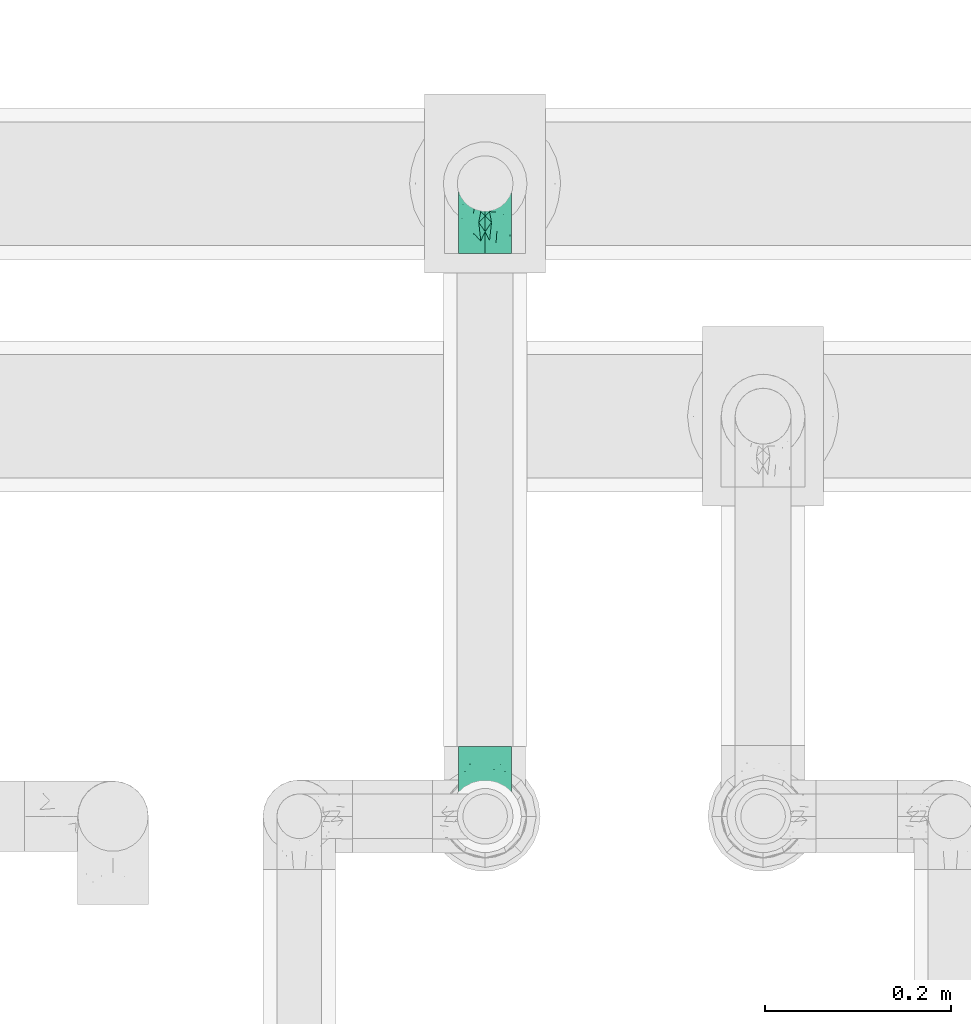
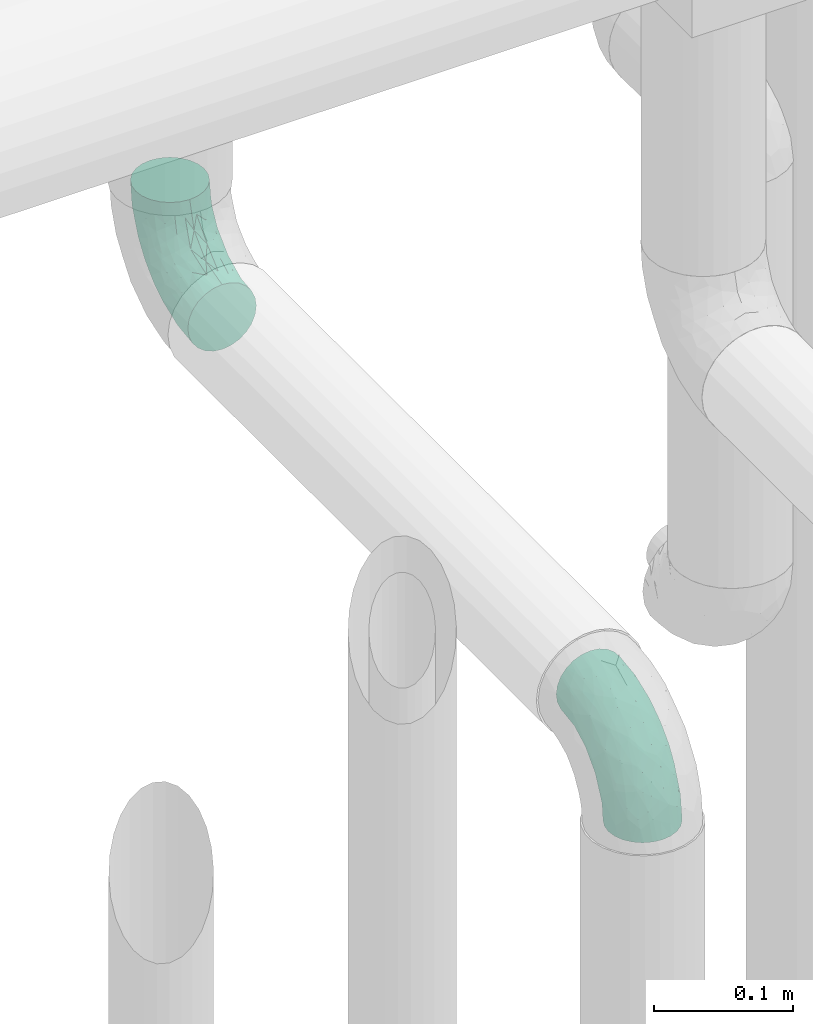
# One storey, part 714 of 827: 2 flow fittings.
"""IFC2X3 building model written with IfcOpenShell, lengths in millimetres."""

from ifc_helpers import new_model, entity, si_unit, converted_unit, derived_unit, direction, frame, origin, place, context, subcontext, project, spatial, faceted_brep, source, transform, mapped, material, type_object, type_shapes, element, save


model = new_model("IFC2X3")

# Units and contexts
model_context = context("Model", 3, precision=0.01, world=origin(), true_north=direction((6.12303176911189e-17, 1.0)))
body_context = subcontext(model_context, "Body", "Model", "MODEL_VIEW")
ifc_project = project(units=[si_unit("LENGTHUNIT", "METRE", prefix="MILLI"), si_unit("AREAUNIT", "SQUARE_METRE"), si_unit("VOLUMEUNIT", "CUBIC_METRE"), converted_unit("PLANEANGLEUNIT", "DEGREE", entity("IfcRatioMeasure", 0.0174532925199433), si_unit("PLANEANGLEUNIT", "RADIAN"), dimensions=[0, 0, 0, 0, 0, 0, 0]), si_unit("MASSUNIT", "GRAM", prefix="KILO"), derived_unit("MASSDENSITYUNIT", [(si_unit("MASSUNIT", "GRAM", prefix="KILO"), 1), (si_unit("LENGTHUNIT", "METRE"), -3)]), derived_unit("MOMENTOFINERTIAUNIT", [(si_unit("LENGTHUNIT", "METRE"), 4)]), si_unit("TIMEUNIT", "SECOND"), si_unit("FREQUENCYUNIT", "HERTZ"), si_unit("THERMODYNAMICTEMPERATUREUNIT", "DEGREE_CELSIUS"), derived_unit("THERMALTRANSMITTANCEUNIT", [(si_unit("MASSUNIT", "GRAM", prefix="KILO"), 1), (si_unit("THERMODYNAMICTEMPERATUREUNIT", "KELVIN"), -1), (si_unit("TIMEUNIT", "SECOND"), -3)]), derived_unit("VOLUMETRICFLOWRATEUNIT", [(si_unit("LENGTHUNIT", "METRE"), 3), (si_unit("TIMEUNIT", "SECOND"), -1)]), derived_unit("MASSFLOWRATEUNIT", [(si_unit("MASSUNIT", "GRAM", prefix="KILO"), 1), (si_unit("TIMEUNIT", "SECOND"), -1)]), derived_unit("ROTATIONALFREQUENCYUNIT", [(si_unit("TIMEUNIT", "SECOND"), -1)]), si_unit("ELECTRICCURRENTUNIT", "AMPERE"), si_unit("ELECTRICVOLTAGEUNIT", "VOLT"), si_unit("POWERUNIT", "WATT"), si_unit("FORCEUNIT", "NEWTON", prefix="KILO"), si_unit("ILLUMINANCEUNIT", "LUX"), si_unit("LUMINOUSFLUXUNIT", "LUMEN"), si_unit("LUMINOUSINTENSITYUNIT", "CANDELA"), derived_unit("USERDEFINED", [(si_unit("MASSUNIT", "GRAM", prefix="KILO"), -1), (si_unit("LENGTHUNIT", "METRE"), -2), (si_unit("TIMEUNIT", "SECOND"), 3), (si_unit("LUMINOUSFLUXUNIT", "LUMEN"), 1)]), derived_unit("LINEARVELOCITYUNIT", [(si_unit("LENGTHUNIT", "METRE"), 1), (si_unit("TIMEUNIT", "SECOND"), -1)]), si_unit("PRESSUREUNIT", "PASCAL"), derived_unit("USERDEFINED", [(si_unit("LENGTHUNIT", "METRE"), -2), (si_unit("MASSUNIT", "GRAM", prefix="KILO"), 1), (si_unit("TIMEUNIT", "SECOND"), -2)]), derived_unit("LINEARFORCEUNIT", [(si_unit("MASSUNIT", "GRAM", prefix="KILO"), 1), (si_unit("LENGTHUNIT", "METRE"), 1), (si_unit("TIMEUNIT", "SECOND"), -2), (si_unit("LENGTHUNIT", "METRE"), -1)]), derived_unit("PLANARFORCEUNIT", [(si_unit("MASSUNIT", "GRAM", prefix="KILO"), 1), (si_unit("LENGTHUNIT", "METRE"), 1), (si_unit("TIMEUNIT", "SECOND"), -2), (si_unit("LENGTHUNIT", "METRE"), -2)])], contexts=[model_context])

# Site, building, storey
site_placement = place(None, origin())
site = spatial("IfcSite", under=ifc_project, at=site_placement, CompositionType="ELEMENT")
building_placement = place(site_placement, origin())
building = spatial("IfcBuilding", under=site, at=building_placement, CompositionType="ELEMENT")
storey_placement = place(building_placement, frame((0.0, 0.0, 28200.0)))
storey = spatial("IfcBuildingStorey", under=building, at=storey_placement, Name="08", CompositionType="ELEMENT", Elevation=28200.0)

# Flow fittings
ifc_material = material()
pipe_fitting_type = type_object("IfcPipeFittingType", Name="ADSK_2", PredefinedType="NOTDEFINED", material=ifc_material)
shared_shape = source(origin(), body_context, "Body", "Brep", [
    faceted_brep([(-75.0, 0.0, -28.5), (-75.0, -7.38, -27.53), (-75.0, -14.25, -24.68), (-75.0, -20.15, -20.15), (-75.0, -24.68, -14.25), (-75.0, -27.53, -7.38), (-75.0, -28.5, 0.0), (-75.0, -27.53, 7.38), (-75.0, -24.68, 14.25), (-75.0, -20.15, 20.15), (-75.0, -14.25, 24.68), (-75.0, -7.38, 27.53), (-75.0, 0.0, 28.5), (-75.0, 7.38, 27.53), (-75.0, 14.25, 24.68), (-75.0, 20.15, 20.15), (-75.0, 24.68, 14.25), (-75.0, 27.53, 7.38), (-75.0, 28.5, 0.0), (-75.0, 27.53, -7.38), (-75.0, 24.68, -14.25), (-75.0, 20.15, -20.15), (-75.0, 14.25, -24.68), (-75.0, 7.38, -27.53), (-7.38, 75.0, -27.53), (-14.25, 75.0, -24.68), (-20.15, 75.0, -20.15), (-24.68, 75.0, -14.25), (-27.53, 75.0, -7.38), (-28.5, 75.0, 0.0), (-27.53, 75.0, 7.38), (-24.68, 75.0, 14.25), (-20.15, 75.0, 20.15), (-14.25, 75.0, 24.68), (-7.38, 75.0, 27.53), (0.0, 75.0, 28.5), (7.38, 75.0, 27.53), (14.25, 75.0, 24.68), (20.15, 75.0, 20.15), (24.68, 75.0, 14.25), (27.53, 75.0, 7.38), (28.5, 75.0, 0.0), (27.53, 75.0, -7.38), (24.68, 75.0, -14.25), (20.15, 75.0, -20.15), (14.25, 75.0, -24.68), (7.38, 75.0, -27.53), (0.0, 75.0, -28.5), (-58.34, -3.09, 28.08), (-53.36, 5.47, 28.42), (-60.98, -26.28, 0.0), (-50.38, -23.9, 9.36), (-2.72, 2.72, 0.0), (3.49, 8.33, 5.39), (-8.47, -3.6, 5.43), (-43.02, -23.43, 0.0), (9.86, 31.5, 19.95), (3.58, 31.64, 24.39), (0.78, 15.8, 19.09), (-55.53, -21.42, 16.31), (-41.02, 15.05, 27.84), (-38.36, 9.63, 28.5), (-24.63, 17.21, 28.45), (14.9, 48.57, 21.5), (-48.57, -14.9, 21.5), (-55.48, -9.89, 25.8), (-22.48, -12.99, 7.59), (-28.59, -16.08, 0.0), (-14.16, -8.73, 0.0), (-38.26, 22.79, 26.22), (-58.0, 11.98, 26.79), (-31.64, -3.58, 24.39), (-39.5, 2.0, 27.82), (-30.52, 53.58, 12.47), (-11.07, 64.24, 26.62), (-4.85, 56.28, 28.4), (-62.79, 17.89, 23.17), (-57.59, 24.67, 18.42), (-50.35, 32.08, 12.72), (-63.79, 27.28, 11.71), (-11.91, 27.95, 28.26), (-21.91, 10.04, 27.08), (-7.9, 23.21, 26.78), (8.73, 14.16, 0.0), (-61.42, 30.11, 4.72), (-44.0, 30.05, 19.91), (-2.0, 39.5, 27.82), (9.89, 55.48, 25.8), (-11.33, 11.33, 24.21), (-17.5, -1.61, 19.5), (13.94, 30.82, 14.87), (19.0, 37.09, 10.84), (21.42, 55.53, 16.31), (3.09, 58.34, 28.08), (-15.17, -4.71, 14.28), (-39.06, -21.55, 5.21), (-35.82, -18.71, 10.31), (23.9, 50.38, 9.36), (-30.11, 61.42, 4.72), (-38.06, 40.7, 14.41), (-33.21, 40.38, 19.56), (26.28, 60.98, 0.0), (-30.82, -13.94, 14.87), (-18.89, 57.68, 23.4), (-24.2, 59.35, 18.31), (-41.53, 41.53, 6.86), (-34.73, 51.75, 0.0), (-51.75, 34.73, 0.0), (-25.37, 39.36, 24.88), (-36.07, 30.61, 23.61), (-32.31, -9.26, 20.83), (-14.02, 50.19, 26.99), (-13.14, 36.54, 28.42), (16.08, 28.59, 0.0), (12.99, 22.48, 7.59), (20.38, 36.25, 5.56), (23.43, 43.02, 0.0), (-48.14, 22.05, 23.83), (-20.29, 38.18, 27.03), (-27.1, 27.1, 27.56), (6.41, 16.13, 12.8), (-4.24, 6.02, 15.65), (-3.26, 3.26, 10.59), (-64.24, 11.07, -26.62), (-48.57, -14.9, -21.5), (-56.28, 4.85, -28.4), (-59.35, 24.2, -18.31), (-57.68, 18.89, -23.4), (9.89, 55.48, -25.8), (3.58, 31.64, -24.39), (-2.0, 39.5, -27.82), (-61.42, 30.11, -4.72), (-30.11, 61.42, -4.72), (-41.53, 41.53, -6.86), (23.9, 50.38, -9.36), (21.42, 55.53, -16.31), (-50.19, 14.02, -26.99), (-39.36, 25.37, -24.88), (3.09, 58.34, -28.08), (-5.47, 53.36, -28.42), (-11.98, 58.0, -26.79), (-50.38, -23.9, -9.36), (13.94, 30.82, -14.87), (14.9, 48.57, -21.5), (-22.79, 38.26, -26.22), (-15.05, 41.02, -27.84), (-55.53, -21.42, -16.31), (-9.63, 38.36, -28.5), (-17.21, 24.63, -28.45), (-22.48, -12.99, -7.59), (-30.61, 36.07, -23.61), (-58.34, -3.09, -28.08), (-37.09, -19.0, -10.84), (-30.82, -13.94, -14.87), (21.55, 39.06, -5.21), (18.71, 35.82, -10.31), (-23.21, 7.9, -26.78), (-39.5, 2.0, -27.82), (-27.95, 11.91, -28.26), (-36.25, -20.38, -5.56), (-24.67, 57.59, -18.42), (3.6, 8.47, -5.43), (-8.33, -3.49, -5.39), (-17.89, 62.79, -23.17), (-32.46, -10.54, -19.76), (-31.64, -3.58, -24.39), (-17.5, -1.61, -19.5), (-10.04, 21.91, -27.08), (-32.08, 50.35, -12.72), (-27.28, 63.79, -11.71), (-30.05, 44.0, -19.91), (-40.38, 33.21, -19.56), (-55.48, -9.89, -25.8), (-53.58, 30.52, -12.47), (12.99, 22.48, -7.59), (9.13, 31.36, -20.52), (-15.17, -4.71, -14.28), (-4.24, 6.02, -15.65), (-3.26, 3.26, -10.59), (-40.7, 38.06, -14.41), (-36.54, 13.14, -28.42), (-22.05, 48.14, -23.83), (-38.18, 20.29, -27.03), (-11.33, 11.33, -24.21), (0.78, 15.8, -19.09), (-27.1, 27.1, -27.56), (6.41, 16.13, -12.8)], [[[0, 1, 2, 3, 4, 5, 6, 7, 8, 9, 10, 11, 12, 13, 14, 15, 16, 17, 18, 19, 20, 21, 22, 23]], [[24, 25, 26, 27, 28, 29, 30, 31, 32, 33, 34, 35, 36, 37, 38, 39, 40, 41, 42, 43, 44, 45, 46, 47]], [[12, 48, 49]], [[50, 51, 7]], [[52, 53, 54]], [[7, 51, 8]], [[55, 51, 50]], [[56, 57, 58]], [[9, 8, 59]], [[60, 61, 62]], [[63, 38, 37]], [[64, 10, 9]], [[64, 65, 10]], [[66, 67, 68]], [[69, 70, 60]], [[65, 71, 72]], [[31, 30, 73]], [[13, 70, 14]], [[34, 74, 75]], [[14, 76, 15]], [[11, 48, 12]], [[77, 78, 79]], [[80, 81, 82]], [[15, 77, 16]], [[52, 83, 53]], [[18, 17, 84]], [[79, 17, 16]], [[12, 49, 13]], [[77, 85, 78]], [[82, 86, 80]], [[37, 87, 63]], [[88, 71, 89]], [[90, 91, 92]], [[39, 38, 92]], [[87, 37, 36]], [[35, 93, 36]], [[94, 66, 54]], [[35, 34, 75]], [[95, 96, 51]], [[39, 97, 40]], [[98, 30, 29]], [[92, 97, 39]], [[99, 100, 73]], [[97, 101, 40]], [[59, 102, 64]], [[63, 87, 57]], [[100, 103, 104]], [[105, 106, 107]], [[51, 59, 8]], [[106, 98, 29]], [[69, 108, 109]], [[84, 105, 107]], [[89, 71, 110]], [[104, 103, 32]], [[33, 32, 103]], [[108, 111, 103]], [[111, 112, 75]], [[74, 103, 111]], [[74, 34, 33]], [[18, 84, 107]], [[10, 65, 11]], [[113, 114, 83]], [[115, 116, 97]], [[70, 13, 49]], [[76, 77, 15]], [[117, 109, 85]], [[32, 31, 104]], [[111, 108, 118]], [[111, 118, 112]], [[93, 75, 86]], [[71, 65, 64]], [[48, 65, 72]], [[110, 102, 89]], [[71, 88, 81]], [[93, 87, 36]], [[86, 82, 57]], [[86, 57, 87]], [[57, 88, 58]], [[59, 51, 96]], [[64, 9, 59]], [[38, 63, 92]], [[90, 92, 63]], [[60, 70, 49]], [[76, 70, 117]], [[103, 100, 108]], [[69, 109, 117]], [[62, 112, 119]], [[86, 75, 112]], [[62, 119, 60]], [[62, 72, 81]], [[89, 58, 88]], [[52, 54, 68]], [[31, 73, 104]], [[100, 104, 73]], [[102, 94, 89]], [[120, 58, 121]], [[89, 94, 121]], [[58, 90, 56]], [[75, 93, 35]], [[87, 93, 86]], [[65, 48, 11]], [[49, 48, 72]], [[60, 49, 61]], [[69, 60, 119]], [[99, 105, 78]], [[98, 105, 73]], [[7, 6, 50]], [[101, 97, 116]], [[101, 41, 40]], [[96, 95, 66]], [[96, 66, 102]], [[91, 114, 115]], [[115, 114, 113]], [[114, 90, 120]], [[79, 84, 17]], [[105, 84, 78]], [[105, 98, 106]], [[73, 30, 98]], [[70, 76, 14]], [[77, 76, 117]], [[49, 72, 61]], [[72, 62, 61]], [[108, 69, 119]], [[70, 69, 117]], [[108, 100, 109]], [[85, 109, 100]], [[85, 100, 99]], [[117, 85, 77]], [[71, 81, 72]], [[82, 81, 88]], [[57, 82, 88]], [[86, 112, 80]], [[112, 62, 80]], [[81, 80, 62]], [[77, 79, 16]], [[84, 79, 78]], [[103, 74, 33]], [[75, 74, 111]], [[105, 99, 73]], [[85, 99, 78]], [[108, 119, 118]], [[112, 118, 119]], [[122, 54, 53]], [[83, 114, 53]], [[120, 53, 114]], [[94, 54, 122]], [[66, 68, 54]], [[71, 64, 110]], [[102, 110, 64]], [[66, 94, 102]], [[121, 94, 122]], [[120, 121, 122]], [[89, 121, 58]], [[120, 122, 53]], [[58, 120, 90]], [[90, 63, 56]], [[57, 56, 63]], [[59, 96, 102]], [[51, 55, 95]], [[55, 67, 95]], [[66, 95, 67]], [[116, 115, 113]], [[91, 115, 97]], [[92, 91, 97]], [[114, 91, 90]], [[123, 23, 22]], [[124, 3, 2]], [[0, 23, 125]], [[23, 123, 125]], [[126, 127, 21]], [[128, 129, 130]], [[107, 131, 18]], [[29, 132, 106]], [[133, 107, 106]], [[134, 135, 43]], [[136, 127, 137]], [[47, 138, 139]], [[140, 24, 139]], [[123, 127, 136]], [[4, 141, 5]], [[135, 142, 143]], [[141, 50, 5]], [[144, 140, 145]], [[141, 4, 146]], [[145, 147, 148]], [[149, 68, 67]], [[22, 21, 127]], [[144, 137, 150]], [[42, 41, 101]], [[151, 1, 0]], [[152, 146, 153]], [[154, 155, 134]], [[156, 157, 158]], [[132, 133, 106]], [[159, 55, 141]], [[29, 28, 132]], [[47, 139, 24]], [[26, 160, 27]], [[52, 161, 83]], [[68, 162, 52]], [[26, 25, 163]], [[140, 25, 24]], [[164, 165, 166]], [[47, 46, 138]], [[158, 167, 156]], [[160, 168, 169]], [[168, 160, 170]], [[171, 127, 126]], [[45, 143, 128]], [[172, 124, 2]], [[131, 19, 18]], [[20, 19, 173]], [[113, 83, 174]], [[44, 43, 135]], [[143, 45, 44]], [[134, 42, 101]], [[175, 129, 143]], [[134, 101, 116]], [[172, 2, 1]], [[124, 172, 165]], [[42, 134, 43]], [[45, 128, 46]], [[176, 177, 178]], [[179, 171, 173]], [[169, 28, 27]], [[4, 3, 146]], [[136, 180, 125]], [[163, 160, 26]], [[181, 150, 170]], [[21, 20, 126]], [[136, 137, 182]], [[136, 182, 180]], [[151, 125, 157]], [[151, 172, 1]], [[157, 156, 165]], [[157, 165, 172]], [[165, 183, 166]], [[129, 128, 143]], [[138, 128, 130]], [[175, 142, 184]], [[129, 183, 167]], [[3, 124, 146]], [[146, 124, 164]], [[135, 134, 155]], [[143, 44, 135]], [[145, 140, 139]], [[163, 140, 181]], [[127, 171, 137]], [[144, 150, 181]], [[148, 180, 185]], [[157, 125, 180]], [[148, 185, 145]], [[148, 130, 167]], [[52, 162, 161]], [[153, 164, 166]], [[20, 173, 126]], [[171, 126, 173]], [[184, 166, 183]], [[176, 153, 166]], [[129, 184, 183]], [[177, 186, 178]], [[125, 151, 0]], [[172, 151, 157]], [[128, 138, 46]], [[139, 138, 130]], [[145, 139, 147]], [[144, 145, 185]], [[179, 133, 168]], [[131, 133, 173]], [[50, 141, 55]], [[50, 6, 5]], [[152, 149, 159]], [[159, 149, 67]], [[149, 153, 176]], [[186, 174, 161]], [[155, 154, 174]], [[155, 174, 142]], [[133, 131, 107]], [[173, 19, 131]], [[169, 132, 28]], [[133, 132, 168]], [[140, 163, 25]], [[160, 163, 181]], [[139, 130, 147]], [[130, 148, 147]], [[137, 144, 185]], [[140, 144, 181]], [[137, 171, 150]], [[170, 150, 171]], [[170, 171, 179]], [[181, 170, 160]], [[129, 167, 130]], [[156, 167, 183]], [[165, 156, 183]], [[157, 180, 158]], [[180, 148, 158]], [[167, 158, 148]], [[160, 169, 27]], [[132, 169, 168]], [[127, 123, 22]], [[125, 123, 136]], [[133, 179, 173]], [[170, 179, 168]], [[137, 185, 182]], [[180, 182, 185]], [[149, 176, 162]], [[149, 162, 68]], [[162, 178, 161]], [[186, 161, 178]], [[174, 83, 161]], [[146, 164, 153]], [[165, 164, 124]], [[177, 166, 184]], [[176, 178, 162]], [[166, 177, 176]], [[186, 184, 142]], [[184, 186, 177]], [[174, 186, 142]], [[142, 175, 143]], [[184, 129, 175]], [[55, 159, 67]], [[152, 159, 141]], [[146, 152, 141]], [[149, 152, 153]], [[135, 155, 142]], [[134, 116, 154]], [[116, 113, 154]], [[174, 154, 113]]]),
])
type_shapes(pipe_fitting_type, [shared_shape])
for number, where, z_axis, x_axis, name in (
    (1, (59297.89, 18180.1, 2502.24), (-1.0, 0.0, 0.0), (0.0, 0.0, -1.0), "ADSK_2"),
    (2, (59297.89, 17500.0, 2502.24), (1.0, 0.0, 0.0), (0.0, -1.0, 0.0), "ADSK_2"),
):
    element("IfcFlowFitting", number, at=place(storey_placement, frame(where, z_axis=z_axis, x_axis=x_axis)), inside=storey, type_object=pipe_fitting_type, material=ifc_material, Name=name, ObjectType="ADSK_2", context=body_context, shape_type="MappedRepresentation", body=[
        mapped(shared_shape, transform((0.0, 0.0, 0.0), scale=1.0)),
    ])

save(model, "model.ifc")
